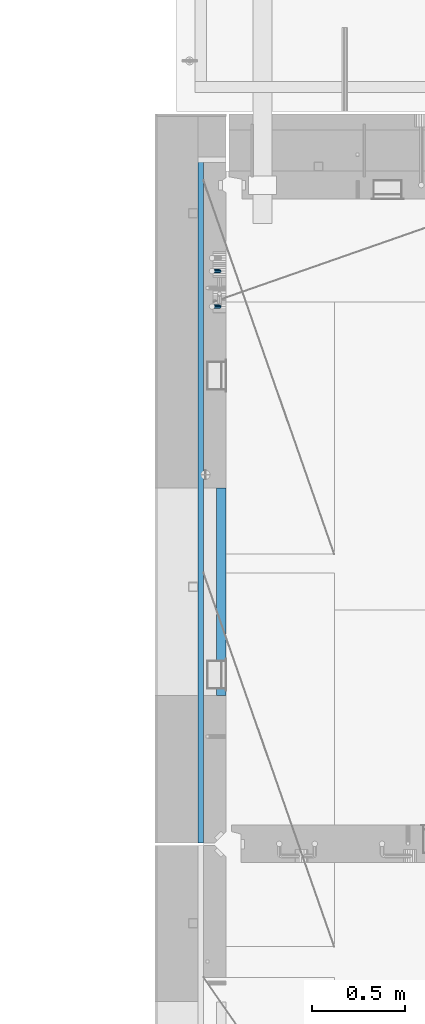
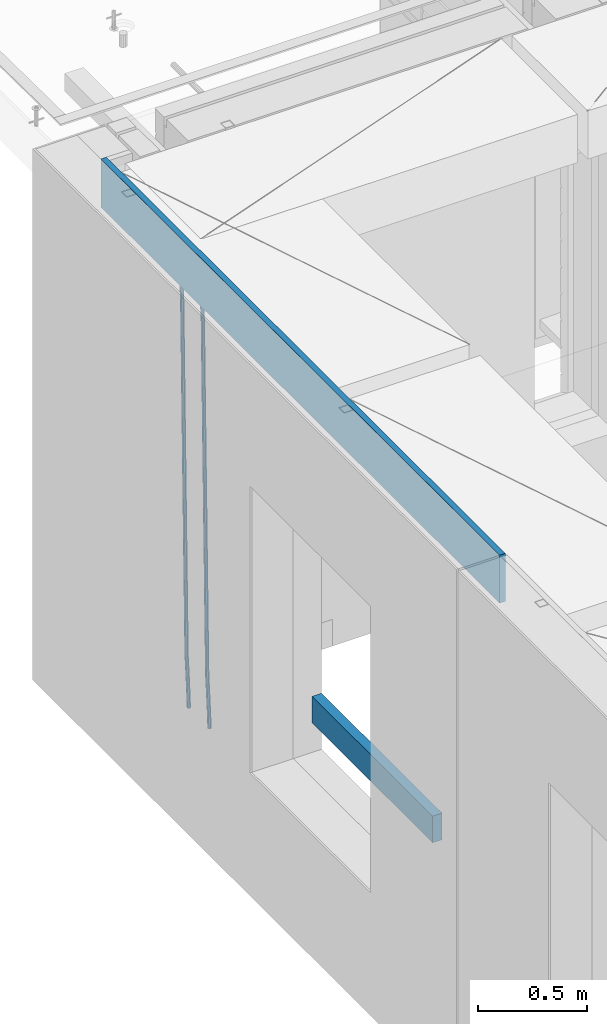
# One storey, part 113 of 350: 4 beams, 1 element without a shape of its own.
"""IFC2X3 building model written with IfcOpenShell, lengths in millimetres."""

from ifc_helpers import new_model, si_unit, frame, origin_with_axes, place, context, subcontext, project, spatial, faceted_brep, material, type_object, element, aggregate, save


model = new_model("IFC2X3")

# Units and contexts
model_context = context("Model", 3, precision=1e-05, world=origin_with_axes())
body_context = subcontext(model_context, "Body", "Model", "MODEL_VIEW")
ifc_project = project(units=[si_unit("LENGTHUNIT", "METRE", prefix="MILLI"), si_unit("AREAUNIT", "SQUARE_METRE"), si_unit("VOLUMEUNIT", "CUBIC_METRE"), si_unit("MASSUNIT", "GRAM", prefix="KILO"), si_unit("TIMEUNIT", "SECOND"), si_unit("PLANEANGLEUNIT", "RADIAN"), si_unit("SOLIDANGLEUNIT", "STERADIAN"), si_unit("THERMODYNAMICTEMPERATUREUNIT", "DEGREE_CELSIUS"), si_unit("LUMINOUSINTENSITYUNIT", "LUMEN")], contexts=[model_context])

# Site, building, storey
site_placement = place(None, origin_with_axes())
site = spatial("IfcSite", under=ifc_project, at=site_placement, CompositionType="ELEMENT")
building_placement = place(site_placement, origin_with_axes())
building = spatial("IfcBuilding", under=site, at=building_placement, CompositionType="ELEMENT")
storey_placement = place(building_placement, origin_with_axes())
storey = spatial("IfcBuildingStorey", under=building, at=storey_placement, Name="2", CompositionType="ELEMENT", Elevation=0.0)

# Assembly, beams
assembly_placement = place(storey_placement, origin_with_axes())
assembly = element("IfcElementAssembly", 1, at=assembly_placement, inside=storey, AssemblyPlace="NOTDEFINED", PredefinedType="REINFORCEMENT_UNIT")
ifc_material_1 = material()
beam_type_1 = type_object("IfcBeamType", Name="D20", PredefinedType="NOTDEFINED")
beam_1_placement = place(assembly_placement, frame((7965.00000227913, 19854.9969072611, 84990.0), z_axis=(-0.999642804636942, -0.000205726999925762, -0.0267249099902983), x_axis=(-0.0267249099948371, 4.30000201934385e-08, 0.999642825806181)))
beam_1 = element("IfcBeam", 2, at=beam_1_placement, type_object=beam_type_1, material=ifc_material_1, Name="JM20", ObjectType="D20", context=body_context, shape_type="Brep", body=[
    faceted_brep([(0.0, -10.0, 0.0), (-4.19531716033816e-08, -7.07106781186667, -7.07106781187031), (60.4266690400545, -7.0710677960451, -7.07106780570757), (60.4266690441291, -9.99999998418934, 6.15546014159918e-09), (0.0, 0.0, -10.0), (60.426669036824, 1.58106558956206e-08, -9.99999999384454), (4.196772351861e-08, 7.07106781186303, -7.07106781186667), (60.4266690363438, 7.07106782768096, -7.07106780570757), (0.0, 10.0, 0.0), (60.4266690388904, 10.0000000158179, 6.15182216279209e-09), (4.196772351861e-08, 7.07106781185939, 7.07106781185939), (60.4266690429649, 7.07106782768096, 7.07106781802577), (0.0, 0.0, 10.0), (60.4266690461809, 1.58179318532348e-08, 10.0000000061555), (-4.19531716033816e-08, -7.07106781187031, 7.07106781185939), (60.4266690466611, -7.07106779605238, 7.07106781802213), (61.0378400410118, -7.07106779588503, -7.07106780564936), (60.991799419251, -9.99999998403655, 6.21366780251265e-09), (61.0569027789461, 1.5985278878361e-08, -9.99999999378269), (61.0378209396877, 7.07106782784831, -7.07106780564936), (60.9917724058905, 10.0000000159635, 6.21366780251265e-09), (60.9457317841297, 7.07106782781193, 7.0710678180767), (60.9266690461809, 1.59488990902901e-08, 10.0000000062028), (60.9457508854539, -7.07106779591413, 7.0710678180767), (61.6489592143771, -7.07106614513759, -7.06310863441468), (61.5568818710308, -9.9999984576425, 0.00735959856683621), (61.6870830769039, 1.71821739058942e-06, -9.99179257185824), (61.6489210170112, 7.07106947854481, -7.06310888312146), (61.556827851804, 10.0000015422847, 0.00735924683976918), (61.4647505084577, 7.07106922979438, 7.07782747982128), (61.4266266459163, 1.36643211590126e-06, 10.0065114172685), (61.464788705809, -7.07106639389531, 7.07782772852806), (176.543135720174, -7.07075579406956, -5.56673531796696), (176.451058376813, -9.99968810657447, 1.50373291501455), (176.581259582701, 0.000312069292704109, -8.49541925541052), (176.543097522794, 7.07137982961285, -5.56673556667374), (176.451004357587, 10.00031189336, 1.50373256329476), (176.35892701424, 7.07137958085514, 8.57420079627263), (176.320803151699, 0.000311717507429421, 11.5028847337162), (176.358965211621, -7.07075604281999, 8.57420104497578), (177.098753836006, -7.07075429323595, -5.55949898843028), (176.98362511232, -9.99968666800123, 1.510669025065), (177.146421932586, 0.000313595905026887, -8.48805862247536), (177.098706077581, 7.07138133041735, -5.55949936166144), (176.983557571715, 10.0003133318824, 1.51066849724157), (176.868428848029, 7.07138095712435, 8.58083651073321), (176.820760751449, 0.000313067976094317, 11.5093961447819), (176.868476606425, -7.07075466652896, 8.58083688396073), (177.654312950661, -7.07075204110879, -5.54863964998367), (177.516135294456, -9.99968450931192, 1.52107783331303), (177.711524267797, 0.000315886711177882, -8.47701274570863), (177.654255632195, 7.07138358250813, -5.54864021007961), (177.516054233929, 10.0003154905207, 1.5210770412159), (177.377876577739, 7.0713830223176, 8.59079452451624), (177.320665260588, 0.000315094497636892, 11.5191676202448), (177.377933896176, -7.07075260129932, 8.59079508461218), (299.436796249574, -7.07025836271714, -3.1681962331204), (299.298618593355, -9.99919083092027, 3.90152125031091), (299.494007566798, 0.000809565110102994, -6.09656932889993), (299.436738931283, 7.07187726089978, -3.16819679320906), (299.298537533061, 10.0008091689197, 3.90152045822106), (299.160359876842, 7.07187670072017, 10.9712379416487), (299.103148559603, 0.000808772889286047, 13.8996110374392), (299.160417195119, -7.07025892290039, 10.9712385017483), (299.98743051647, -7.07025613056248, -3.15743315966392), (299.971788958996, -9.99918809853989, 3.91467979818117), (299.993912075952, 0.000811591617093654, -6.08679785393178), (299.987423933868, 7.07187949325817, -3.1574327280432), (299.971753863239, 10.0008119014747, 3.91467990454839), (299.95611230444, 7.07187992653053, 10.9867922621015), (299.949630744944, 0.000812204350950196, 13.9161569563694), (299.956118887014, -7.07025569729012, 10.9867918304735), (300.538107039494, -7.07025785017686, -3.16575821840888), (300.644985195438, -9.99919020432935, 3.90450175465594), (300.493854948218, 0.000810030429420294, -6.09435592770024), (300.538151196495, 7.071877773491, -3.16575855385963), (300.645047642858, 10.0008097955724, 3.90450128024895), (300.751925798773, 7.07187744142357, 10.9747612533101), (300.796177890064, 0.000809560813650023, 13.9033589625978), (300.751881641787, -7.07025818224065, 10.9747615887682), (2293.36490490142, -7.07648090940347, -33.2930642912361), (2293.47178305736, -10.0054132635523, -26.2228043181785), (2293.32065281013, -0.00541302880083094, -36.2216620005347), (2293.36494905842, 7.06565471425711, -33.2930646266868), (2293.47184550477, 9.99458673634581, -26.2228047925819), (2293.57872366071, 7.06565438219332, -19.1525448195243), (2293.62297575199, -0.00541349841296324, -16.2239471102366), (2293.57867950371, -7.0764812414709, -19.1525444840736), (2294.0658245362, -7.07648309818615, -33.3036607065333), (2294.05312277409, -10.0054150789219, -26.2315929392535), (2294.10928714235, -0.00541549149056664, -36.2335844756526), (2294.15805078732, 7.06565223761572, -33.3050546393533), (2294.18355038921, 9.99458451388637, -26.2335642579346), (2294.17084862708, 7.06565253314329, -19.1614964906439), (2294.12738602093, -0.00541507354500936, -16.2315727215355), (2294.07862237596, -7.07648280265857, -19.1601025578348), (2294.76670261032, -7.08562269121467, -33.294332712383), (2294.63442802057, -10.0129954178956, -26.2238563411993), (2294.89787471293, -0.0156988342423574, -36.2230891548279), (2294.95110548967, 7.05531064255774, -33.2944998654275), (2294.89521307347, 9.98530428734011, -26.2240927312887), (2294.76293848372, 7.0579315606592, -19.1536163601049), (2294.63176638114, -0.0119922963167483, -16.2248599176673), (2294.57853560438, -7.08300177311321, -19.1534492070678), (2316.52657204497, -7.36937582653991, -33.0047303660212), (2316.39429745522, -10.2967485532172, -25.9342539948302), (2316.65774414754, -0.299451969567599, -35.9334868084661), (2316.7109749243, 6.7715575072325, -33.0048975190657), (2316.65508250811, 9.70155115201487, -25.9344903849269), (2316.52280791836, 6.7741784253376, -18.8640140137468), (2316.39163581574, -0.295745431634714, -15.9352575713092), (2316.33840503903, -7.36675490843481, -18.863846860706), (2317.16202064224, -7.37766220584308, -32.9962731735213), (2317.05438744847, -10.3053562613532, -25.9254688497131), (2317.23607125619, -0.306993473008333, -35.925789846493), (2317.23316144495, 6.76474808850253, -32.9979477328052), (2317.15499573652, 9.6950321815566, -25.9278370341635), (2317.04736254275, 6.7673381260538, -18.8570327103698), (2316.97331192881, -0.303330606784584, -15.9275160373909), (2316.97622174003, -7.37507216829545, -18.8553581510787), (2317.79752306276, -7.37578610372293, -32.9880110666527), (2317.71453320107, -10.3033876998124, -25.9168792378296), (2317.81444760226, -0.305295583297266, -35.918287695793), (2317.75539265381, 6.76628640723357, -32.9911928173897), (2317.65495180529, 9.69652304524061, -25.9213789128698), (2317.5719619436, 6.76892144914746, -18.8502470840467), (2317.55503740412, -0.301569071270933, -15.9199704549137), (2317.61409235255, -7.3731510618054, -18.847065333317), (2417.8183084176, -7.07752398473531, -31.6906369377139), (2417.73531855589, -10.0051255808248, -24.6195051088798), (2417.83523295709, -0.007033464313281, -34.6209135668432), (2417.77617800863, 7.06454852621755, -31.6938186884508), (2417.67573716014, 9.99478516423187, -24.6240047839383), (2417.59274729842, 7.06718356813872, -17.5528729551006), (2417.57582275895, -0.00330695228694822, -14.6225963259749), (2417.6348777074, -7.07488894281778, -17.5496912043673)], [[[0, 1, 2, 3]], [[1, 4, 5, 2]], [[4, 6, 7, 5]], [[6, 8, 9, 7]], [[8, 10, 11, 9]], [[10, 12, 13, 11]], [[12, 14, 15, 13]], [[14, 0, 3, 15]], [[14, 12, 10, 8, 6, 4, 1, 0]], [[3, 2, 16, 17]], [[2, 5, 18, 16]], [[5, 7, 19, 18]], [[7, 9, 20, 19]], [[9, 11, 21, 20]], [[11, 13, 22, 21]], [[13, 15, 23, 22]], [[15, 3, 17, 23]], [[17, 16, 24, 25]], [[16, 18, 26, 24]], [[18, 19, 27, 26]], [[19, 20, 28, 27]], [[20, 21, 29, 28]], [[21, 22, 30, 29]], [[22, 23, 31, 30]], [[23, 17, 25, 31]], [[25, 24, 32, 33]], [[24, 26, 34, 32]], [[26, 27, 35, 34]], [[27, 28, 36, 35]], [[28, 29, 37, 36]], [[29, 30, 38, 37]], [[30, 31, 39, 38]], [[31, 25, 33, 39]], [[33, 32, 40, 41]], [[32, 34, 42, 40]], [[34, 35, 43, 42]], [[35, 36, 44, 43]], [[36, 37, 45, 44]], [[37, 38, 46, 45]], [[38, 39, 47, 46]], [[39, 33, 41, 47]], [[41, 40, 48, 49]], [[40, 42, 50, 48]], [[42, 43, 51, 50]], [[43, 44, 52, 51]], [[44, 45, 53, 52]], [[45, 46, 54, 53]], [[46, 47, 55, 54]], [[47, 41, 49, 55]], [[49, 48, 56, 57]], [[48, 50, 58, 56]], [[50, 51, 59, 58]], [[51, 52, 60, 59]], [[52, 53, 61, 60]], [[53, 54, 62, 61]], [[54, 55, 63, 62]], [[55, 49, 57, 63]], [[57, 56, 64, 65]], [[56, 58, 66, 64]], [[58, 59, 67, 66]], [[59, 60, 68, 67]], [[60, 61, 69, 68]], [[61, 62, 70, 69]], [[62, 63, 71, 70]], [[63, 57, 65, 71]], [[65, 64, 72, 73]], [[64, 66, 74, 72]], [[66, 67, 75, 74]], [[67, 68, 76, 75]], [[68, 69, 77, 76]], [[69, 70, 78, 77]], [[70, 71, 79, 78]], [[71, 65, 73, 79]], [[73, 72, 80, 81]], [[72, 74, 82, 80]], [[74, 75, 83, 82]], [[75, 76, 84, 83]], [[76, 77, 85, 84]], [[77, 78, 86, 85]], [[78, 79, 87, 86]], [[79, 73, 81, 87]], [[81, 80, 88, 89]], [[80, 82, 90, 88]], [[82, 83, 91, 90]], [[83, 84, 92, 91]], [[84, 85, 93, 92]], [[85, 86, 94, 93]], [[86, 87, 95, 94]], [[87, 81, 89, 95]], [[89, 88, 96, 97]], [[88, 90, 98, 96]], [[90, 91, 99, 98]], [[91, 92, 100, 99]], [[92, 93, 101, 100]], [[93, 94, 102, 101]], [[94, 95, 103, 102]], [[95, 89, 97, 103]], [[97, 96, 104, 105]], [[96, 98, 106, 104]], [[98, 99, 107, 106]], [[99, 100, 108, 107]], [[100, 101, 109, 108]], [[101, 102, 110, 109]], [[102, 103, 111, 110]], [[103, 97, 105, 111]], [[105, 104, 112, 113]], [[104, 106, 114, 112]], [[106, 107, 115, 114]], [[107, 108, 116, 115]], [[108, 109, 117, 116]], [[109, 110, 118, 117]], [[110, 111, 119, 118]], [[111, 105, 113, 119]], [[113, 112, 120, 121]], [[112, 114, 122, 120]], [[114, 115, 123, 122]], [[115, 116, 124, 123]], [[116, 117, 125, 124]], [[117, 118, 126, 125]], [[118, 119, 127, 126]], [[119, 113, 121, 127]], [[121, 120, 128, 129]], [[120, 122, 130, 128]], [[122, 123, 131, 130]], [[123, 124, 132, 131]], [[124, 125, 133, 132]], [[125, 126, 134, 133]], [[126, 127, 135, 134]], [[127, 121, 129, 135]], [[130, 131, 132, 133, 134, 135, 129, 128]]]),
])
beam_2_placement = place(assembly_placement, frame((7965.00000227913, 20044.9969072611, 84990.0), z_axis=(-0.999642804636942, -0.000205726999925762, -0.0267249099902983), x_axis=(-0.0267249099948371, 4.30000201934385e-08, 0.999642825806181)))
beam_2 = element("IfcBeam", 3, at=beam_2_placement, type_object=beam_type_1, material=ifc_material_1, Name="JM20", ObjectType="D20", context=body_context, shape_type="Brep", body=[
    faceted_brep([(0.0, -10.0, 0.0), (-4.19531716033816e-08, -7.07106781186667, -7.07106781187031), (60.4266690400545, -7.0710677960451, -7.07106780570757), (60.4266690441291, -9.99999998418934, 6.15546014159918e-09), (0.0, 0.0, -10.0), (60.426669036824, 1.58106558956206e-08, -9.99999999384454), (4.196772351861e-08, 7.07106781186303, -7.07106781186667), (60.4266690363438, 7.07106782768096, -7.07106780570757), (0.0, 10.0, 0.0), (60.4266690388904, 10.0000000158179, 6.15182216279209e-09), (4.196772351861e-08, 7.07106781185939, 7.07106781185939), (60.4266690429649, 7.07106782768096, 7.07106781802577), (0.0, 0.0, 10.0), (60.4266690461809, 1.58179318532348e-08, 10.0000000061555), (-4.19531716033816e-08, -7.07106781187031, 7.07106781185939), (60.4266690466611, -7.07106779605238, 7.07106781802213), (61.0378400410118, -7.07106779588503, -7.07106780564936), (60.991799419251, -9.99999998403655, 6.21366780251265e-09), (61.0569027789461, 1.5985278878361e-08, -9.99999999378269), (61.0378209396877, 7.07106782784831, -7.07106780564936), (60.9917724058905, 10.0000000159635, 6.21366780251265e-09), (60.9457317841297, 7.07106782781193, 7.0710678180767), (60.9266690461809, 1.59488990902901e-08, 10.0000000062028), (60.9457508854539, -7.07106779591413, 7.0710678180767), (61.6489592143771, -7.07106614513759, -7.06310863441468), (61.5568818710308, -9.9999984576425, 0.00735959856683621), (61.6870830769039, 1.71821739058942e-06, -9.99179257185824), (61.6489210170112, 7.07106947854481, -7.06310888312146), (61.556827851804, 10.0000015422847, 0.00735924683976918), (61.4647505084577, 7.07106922979438, 7.07782747982128), (61.4266266459163, 1.36643211590126e-06, 10.0065114172685), (61.464788705809, -7.07106639389531, 7.07782772852806), (176.543135720174, -7.07075579406956, -5.56673531796696), (176.451058376813, -9.99968810657447, 1.50373291501455), (176.581259582701, 0.000312069292704109, -8.49541925541052), (176.543097522794, 7.07137982961285, -5.56673556667374), (176.451004357587, 10.00031189336, 1.50373256329476), (176.35892701424, 7.07137958085514, 8.57420079627263), (176.320803151699, 0.000311717507429421, 11.5028847337162), (176.358965211621, -7.07075604281999, 8.57420104497578), (177.098753836006, -7.07075429323595, -5.55949898843028), (176.98362511232, -9.99968666800123, 1.510669025065), (177.146421932586, 0.000313595905026887, -8.48805862247536), (177.098706077581, 7.07138133041735, -5.55949936166144), (176.983557571715, 10.0003133318824, 1.51066849724157), (176.868428848029, 7.07138095712435, 8.58083651073321), (176.820760751449, 0.000313067976094317, 11.5093961447819), (176.868476606425, -7.07075466652896, 8.58083688396073), (177.654312950661, -7.07075204110879, -5.54863964998367), (177.516135294456, -9.99968450931192, 1.52107783331303), (177.711524267797, 0.000315886711177882, -8.47701274570863), (177.654255632195, 7.07138358250813, -5.54864021007961), (177.516054233929, 10.0003154905207, 1.5210770412159), (177.377876577739, 7.0713830223176, 8.59079452451624), (177.320665260588, 0.000315094497636892, 11.5191676202448), (177.377933896176, -7.07075260129932, 8.59079508461218), (299.436796249574, -7.07025836271714, -3.1681962331204), (299.298618593355, -9.99919083092027, 3.90152125031091), (299.494007566798, 0.000809565110102994, -6.09656932889993), (299.436738931283, 7.07187726089978, -3.16819679320906), (299.298537533061, 10.0008091689197, 3.90152045822106), (299.160359876842, 7.07187670072017, 10.9712379416487), (299.103148559603, 0.000808772889286047, 13.8996110374392), (299.160417195119, -7.07025892290039, 10.9712385017483), (299.98743051647, -7.07025613056248, -3.15743315966392), (299.971788958996, -9.99918809853989, 3.91467979818117), (299.993912075952, 0.000811591617093654, -6.08679785393178), (299.987423933868, 7.07187949325817, -3.1574327280432), (299.971753863239, 10.0008119014747, 3.91467990454839), (299.95611230444, 7.07187992653053, 10.9867922621015), (299.949630744944, 0.000812204350950196, 13.9161569563694), (299.956118887014, -7.07025569729012, 10.9867918304735), (300.538107039494, -7.07025785017686, -3.16575821840888), (300.644985195438, -9.99919020432935, 3.90450175465594), (300.493854948218, 0.000810030429420294, -6.09435592770024), (300.538151196495, 7.071877773491, -3.16575855385963), (300.645047642858, 10.0008097955724, 3.90450128024895), (300.751925798773, 7.07187744142357, 10.9747612533101), (300.796177890064, 0.000809560813650023, 13.9033589625978), (300.751881641787, -7.07025818224065, 10.9747615887682), (2293.36490490142, -7.07648090940347, -33.2930642912361), (2293.47178305736, -10.0054132635523, -26.2228043181785), (2293.32065281013, -0.00541302880083094, -36.2216620005347), (2293.36494905842, 7.06565471425711, -33.2930646266868), (2293.47184550477, 9.99458673634581, -26.2228047925819), (2293.57872366071, 7.06565438219332, -19.1525448195243), (2293.62297575199, -0.00541349841296324, -16.2239471102366), (2293.57867950371, -7.0764812414709, -19.1525444840736), (2294.0658245362, -7.07648309818615, -33.3036607065333), (2294.05312277409, -10.0054150789219, -26.2315929392535), (2294.10928714235, -0.00541549149056664, -36.2335844756526), (2294.15805078732, 7.06565223761572, -33.3050546393533), (2294.18355038921, 9.99458451388637, -26.2335642579346), (2294.17084862708, 7.06565253314329, -19.1614964906439), (2294.12738602093, -0.00541507354500936, -16.2315727215355), (2294.07862237596, -7.07648280265857, -19.1601025578348), (2294.76670261032, -7.08562269121467, -33.294332712383), (2294.63442802057, -10.0129954178956, -26.2238563411993), (2294.89787471293, -0.0156988342423574, -36.2230891548279), (2294.95110548967, 7.05531064255774, -33.2944998654275), (2294.89521307347, 9.98530428734011, -26.2240927312887), (2294.76293848372, 7.0579315606592, -19.1536163601049), (2294.63176638114, -0.0119922963167483, -16.2248599176673), (2294.57853560438, -7.08300177311321, -19.1534492070678), (2316.52657204497, -7.36937582653991, -33.0047303660212), (2316.39429745522, -10.2967485532172, -25.9342539948302), (2316.65774414754, -0.299451969567599, -35.9334868084661), (2316.7109749243, 6.7715575072325, -33.0048975190657), (2316.65508250811, 9.70155115201487, -25.9344903849269), (2316.52280791836, 6.7741784253376, -18.8640140137468), (2316.39163581574, -0.295745431634714, -15.9352575713092), (2316.33840503903, -7.36675490843481, -18.863846860706), (2317.16202064224, -7.37766220584308, -32.9962731735213), (2317.05438744847, -10.3053562613532, -25.9254688497131), (2317.23607125619, -0.306993473008333, -35.925789846493), (2317.23316144495, 6.76474808850253, -32.9979477328052), (2317.15499573652, 9.6950321815566, -25.9278370341635), (2317.04736254275, 6.7673381260538, -18.8570327103698), (2316.97331192881, -0.303330606784584, -15.9275160373909), (2316.97622174003, -7.37507216829545, -18.8553581510787), (2317.79752306276, -7.37578610372293, -32.9880110666527), (2317.71453320107, -10.3033876998124, -25.9168792378296), (2317.81444760226, -0.305295583297266, -35.918287695793), (2317.75539265381, 6.76628640723357, -32.9911928173897), (2317.65495180529, 9.69652304524061, -25.9213789128698), (2317.5719619436, 6.76892144914746, -18.8502470840467), (2317.55503740412, -0.301569071270933, -15.9199704549137), (2317.61409235255, -7.3731510618054, -18.847065333317), (2417.8183084176, -7.07752398473531, -31.6906369377139), (2417.73531855589, -10.0051255808248, -24.6195051088798), (2417.83523295709, -0.007033464313281, -34.6209135668432), (2417.77617800863, 7.06454852621755, -31.6938186884508), (2417.67573716014, 9.99478516423187, -24.6240047839383), (2417.59274729842, 7.06718356813872, -17.5528729551006), (2417.57582275895, -0.00330695228694822, -14.6225963259749), (2417.6348777074, -7.07488894281778, -17.5496912043673)], [[[0, 1, 2, 3]], [[1, 4, 5, 2]], [[4, 6, 7, 5]], [[6, 8, 9, 7]], [[8, 10, 11, 9]], [[10, 12, 13, 11]], [[12, 14, 15, 13]], [[14, 0, 3, 15]], [[14, 12, 10, 8, 6, 4, 1, 0]], [[3, 2, 16, 17]], [[2, 5, 18, 16]], [[5, 7, 19, 18]], [[7, 9, 20, 19]], [[9, 11, 21, 20]], [[11, 13, 22, 21]], [[13, 15, 23, 22]], [[15, 3, 17, 23]], [[17, 16, 24, 25]], [[16, 18, 26, 24]], [[18, 19, 27, 26]], [[19, 20, 28, 27]], [[20, 21, 29, 28]], [[21, 22, 30, 29]], [[22, 23, 31, 30]], [[23, 17, 25, 31]], [[25, 24, 32, 33]], [[24, 26, 34, 32]], [[26, 27, 35, 34]], [[27, 28, 36, 35]], [[28, 29, 37, 36]], [[29, 30, 38, 37]], [[30, 31, 39, 38]], [[31, 25, 33, 39]], [[33, 32, 40, 41]], [[32, 34, 42, 40]], [[34, 35, 43, 42]], [[35, 36, 44, 43]], [[36, 37, 45, 44]], [[37, 38, 46, 45]], [[38, 39, 47, 46]], [[39, 33, 41, 47]], [[41, 40, 48, 49]], [[40, 42, 50, 48]], [[42, 43, 51, 50]], [[43, 44, 52, 51]], [[44, 45, 53, 52]], [[45, 46, 54, 53]], [[46, 47, 55, 54]], [[47, 41, 49, 55]], [[49, 48, 56, 57]], [[48, 50, 58, 56]], [[50, 51, 59, 58]], [[51, 52, 60, 59]], [[52, 53, 61, 60]], [[53, 54, 62, 61]], [[54, 55, 63, 62]], [[55, 49, 57, 63]], [[57, 56, 64, 65]], [[56, 58, 66, 64]], [[58, 59, 67, 66]], [[59, 60, 68, 67]], [[60, 61, 69, 68]], [[61, 62, 70, 69]], [[62, 63, 71, 70]], [[63, 57, 65, 71]], [[65, 64, 72, 73]], [[64, 66, 74, 72]], [[66, 67, 75, 74]], [[67, 68, 76, 75]], [[68, 69, 77, 76]], [[69, 70, 78, 77]], [[70, 71, 79, 78]], [[71, 65, 73, 79]], [[73, 72, 80, 81]], [[72, 74, 82, 80]], [[74, 75, 83, 82]], [[75, 76, 84, 83]], [[76, 77, 85, 84]], [[77, 78, 86, 85]], [[78, 79, 87, 86]], [[79, 73, 81, 87]], [[81, 80, 88, 89]], [[80, 82, 90, 88]], [[82, 83, 91, 90]], [[83, 84, 92, 91]], [[84, 85, 93, 92]], [[85, 86, 94, 93]], [[86, 87, 95, 94]], [[87, 81, 89, 95]], [[89, 88, 96, 97]], [[88, 90, 98, 96]], [[90, 91, 99, 98]], [[91, 92, 100, 99]], [[92, 93, 101, 100]], [[93, 94, 102, 101]], [[94, 95, 103, 102]], [[95, 89, 97, 103]], [[97, 96, 104, 105]], [[96, 98, 106, 104]], [[98, 99, 107, 106]], [[99, 100, 108, 107]], [[100, 101, 109, 108]], [[101, 102, 110, 109]], [[102, 103, 111, 110]], [[103, 97, 105, 111]], [[105, 104, 112, 113]], [[104, 106, 114, 112]], [[106, 107, 115, 114]], [[107, 108, 116, 115]], [[108, 109, 117, 116]], [[109, 110, 118, 117]], [[110, 111, 119, 118]], [[111, 105, 113, 119]], [[113, 112, 120, 121]], [[112, 114, 122, 120]], [[114, 115, 123, 122]], [[115, 116, 124, 123]], [[116, 117, 125, 124]], [[117, 118, 126, 125]], [[118, 119, 127, 126]], [[119, 113, 121, 127]], [[121, 120, 128, 129]], [[120, 122, 130, 128]], [[122, 123, 131, 130]], [[123, 124, 132, 131]], [[124, 125, 133, 132]], [[125, 126, 134, 133]], [[126, 127, 135, 134]], [[127, 121, 129, 135]], [[130, 131, 132, 133, 134, 135, 129, 128]]]),
])
ifc_material_2 = material(Name="TIMBER/T24")
beam_type_2 = type_object("IfcBeamType", PredefinedType="NOTDEFINED")
beam_3_placement = place(assembly_placement, frame((7975.00000026382, 18885.0004107749, 85685.0), z_axis=(0.0, 0.0, 1.0), x_axis=(0.0, -1.0, 0.0)))
beam_3 = element("IfcBeam", 4, at=beam_3_placement, type_object=beam_type_2, material=ifc_material_2, context=body_context, shape_type="Brep", body=[
    faceted_brep([(-3.63797880709171e-12, 24.9999999999964, -75.0), (-3.63797880709171e-12, 24.9999999999964, 75.0), (1110.0, 24.9999999999964, 75.0), (1110.0, 24.9999999999964, -75.0), (0.0, -25.0000000000073, 75.0), (1110.0, -25.0000000000073, 75.0), (0.0, -25.0000000000073, -75.0), (1110.0, -25.0000000000073, -75.0)], [[[0, 1, 2, 3]], [[1, 4, 5, 2]], [[4, 6, 7, 5]], [[6, 0, 3, 7]], [[5, 7, 3, 2]], [[6, 4, 1, 0]]]),
])
ifc_material_3 = material(Name="CONCRETE/C25/30")
beam_type_3 = type_object("IfcBeamType", Name="270X30", PredefinedType="NOTDEFINED")
beam_4_placement = place(assembly_placement, frame((7865.0, 20654.9951872276, 87605.0), z_axis=(0.0, 0.0, 1.0), x_axis=(0.0, -1.0, 0.0)))
beam_4 = element("IfcBeam", 5, at=beam_4_placement, type_object=beam_type_3, material=ifc_material_3, ObjectType="270X30", context=body_context, shape_type="Brep", body=[
    faceted_brep([(0.0, 15.0, -135.0), (0.0, 15.0, 135.0), (3669.99518722759, 15.0, 135.0), (3669.99518722759, 15.0, -135.0), (0.0, -15.0, 135.0), (3669.99518722759, -15.0, 135.0), (0.0, -15.0, -135.0), (3669.99518722759, -15.0, -135.0)], [[[0, 1, 2, 3]], [[1, 4, 5, 2]], [[4, 6, 7, 5]], [[6, 0, 3, 7]], [[5, 7, 3, 2]], [[6, 4, 1, 0]]]),
])
aggregate(assembly, [beam_1, beam_2, beam_4, beam_3])

save(model, "model.ifc")
